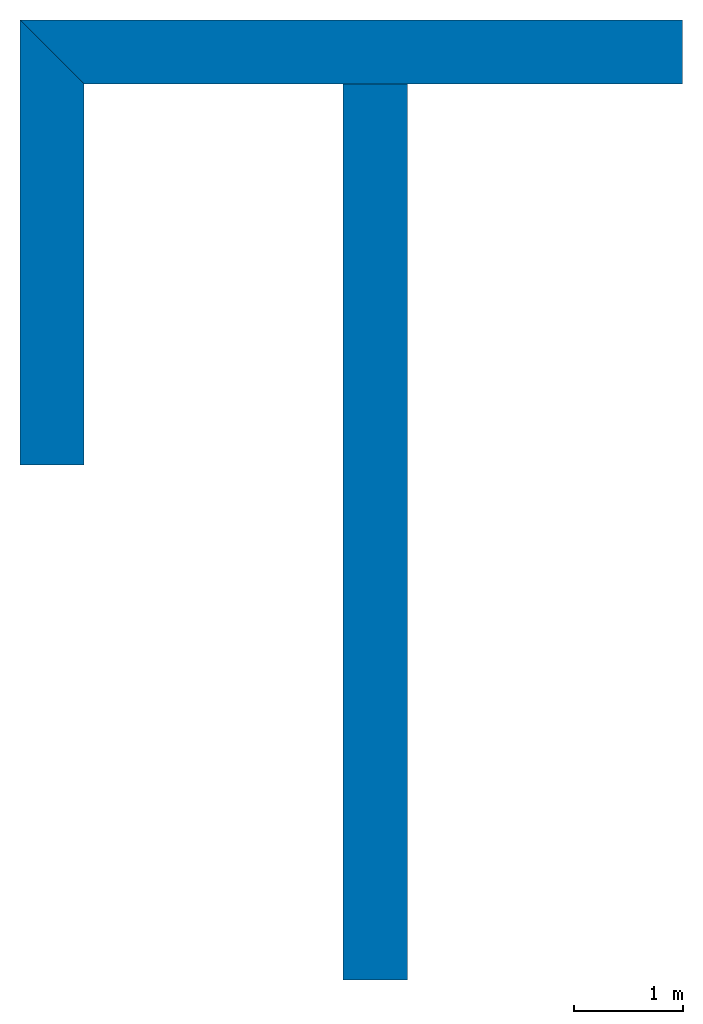
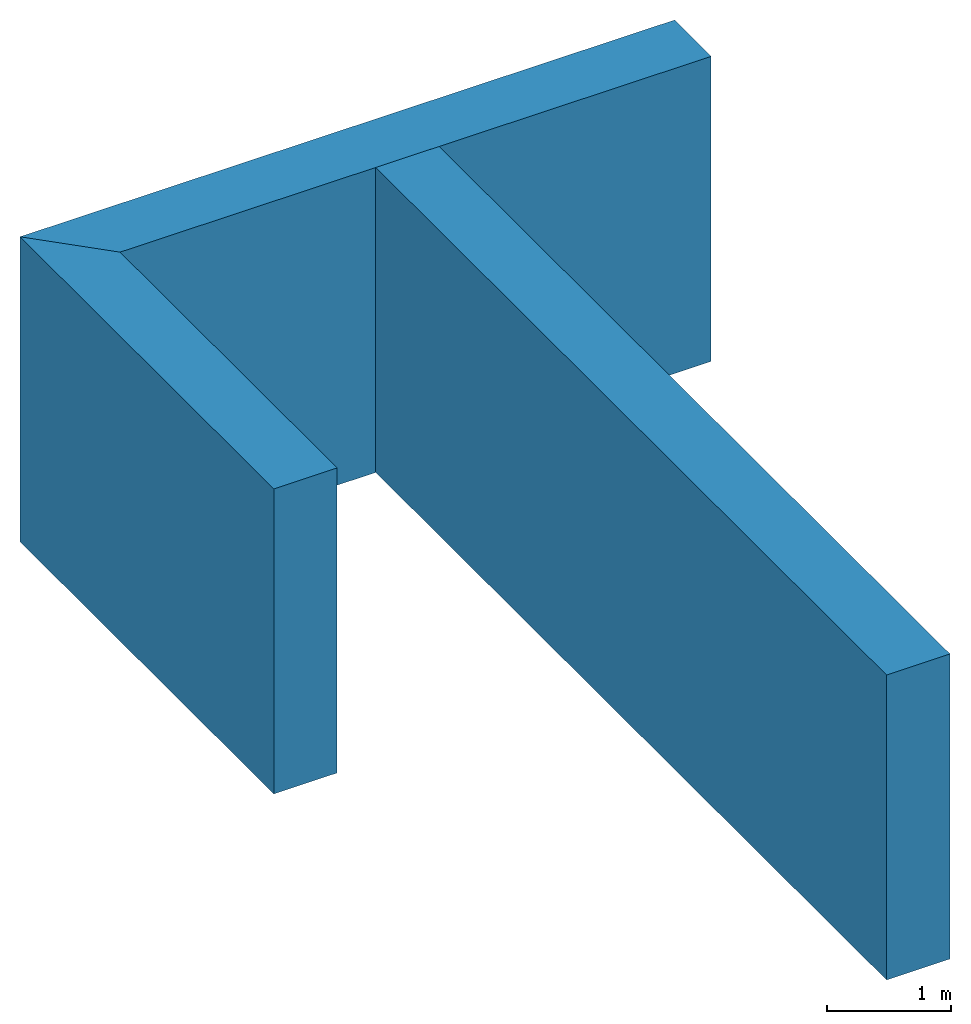
# One storey: 3 walls.
"""IFC4 building model written with IfcOpenShell, lengths in metres."""

from ifc_helpers import new_model, entity, si_unit, converted_unit, frame, origin_with_axes, origin_2d_with_axis, place, context, subcontext, project, spatial, line, indexed_curve, outline, extrude, material, layer, layer_set, layer_usage, type_object, element, save


model = new_model("IFC4")

# Units and contexts
model_context = context("Model", 3, precision=1e-05, world=origin_with_axes())
plan_context = context("Plan", 2, precision=1e-05, world=origin_2d_with_axis())
body_context = subcontext(model_context, "Body", "Model", "MODEL_VIEW")
ifc_project = project(units=[si_unit("AREAUNIT", "SQUARE_METRE"), si_unit("VOLUMEUNIT", "CUBIC_METRE"), si_unit("LENGTHUNIT", "METRE"), converted_unit("PLANEANGLEUNIT", "degree", entity("IfcReal", 0.0174532925199433), si_unit("PLANEANGLEUNIT", "RADIAN"), dimensions=[0, 0, 0, 0, 0, 0, 0])], contexts=[model_context, plan_context])

# Site, building, storey
site_placement = place(None, origin_with_axes())
site = spatial("IfcSite", under=ifc_project, at=site_placement)
building_placement = place(site_placement, origin_with_axes())
building = spatial("IfcBuilding", under=site, at=building_placement, Name="Building")
storey_placement = place(building_placement, origin_with_axes())
storey = spatial("IfcBuildingStorey", under=building, at=storey_placement, Name="Storey")

# Walls
ifc_material_1 = material(Name="Stucco")
ifc_layer_1 = layer(ifc_material_1, 0.0199999995529652, ventilated=False, Priority=80)
ifc_material_2 = material(Name="Brick")
ifc_layer_2 = layer(ifc_material_2, 0.300000011920929, Priority=20)
ifc_material_3 = material(Name="Insulation")
ifc_layer_3 = layer(ifc_material_3, 0.25, Priority=50)
ifc_layer_4 = layer(ifc_material_1, 0.0199999995529652, Priority=80)
ifc_layer_set = layer_set([ifc_layer_1, ifc_layer_2, ifc_layer_3, ifc_layer_4], Name="Brick Wall Layer Set")
ifc_layer_usage_1 = layer_usage(ifc_layer_set, "AXIS2", "POSITIVE", 0.0)
wall_type = type_object("IfcWallType", Name="Brick wall", PredefinedType="SOLIDWALL", material=ifc_layer_set)
wall_1_placement = place(storey_placement, frame((7.1723007977198e-07, 9.5, 0.0), z_axis=(0.0, 0.0, 1.0), x_axis=(1.0, -2.38418579101562e-07, 0.0)))
element("IfcWall", 1, at=wall_1_placement, inside=storey, type_object=wall_type, material=ifc_layer_usage_1, Name="Wall", context=body_context, shape_type="SweptSolid", body=[
    extrude(outline(indexed_curve([(0.0, 0.0), (-0.0200000028113789, 0.0199999995529652), (-0.320000063608517, 0.320000011473894), (-0.57000010433869, 0.570000011473894), (-0.590000107150069, 0.590000011026859), (5.50000000000024, 0.590000011026859), (5.50000000000024, 0.0)], segments=[line(1, 2, 3, 4, 5, 6, 7, 1)])), origin_with_axes(), (0.0, 0.0, 1.0), 3.0),
])
ifc_layer_usage_2 = layer_usage(ifc_layer_set, "AXIS2", "NEGATIVE", 0.0)
wall_2_placement = place(storey_placement, frame((2.37892355769873, 1.26785459701176, 0.0), z_axis=(0.0, 0.0, 1.0), x_axis=(7.54979012640431e-08, 0.999999999999997, 0.0)))
element("IfcWall", 2, at=wall_2_placement, inside=storey, type_object=wall_type, material=ifc_layer_usage_2, Name="Wall", context=body_context, shape_type="SweptSolid", body=[
    extrude(outline(indexed_curve([(0.0, -0.590000011026859), (0.0, 0.0), (8.23214483580871, 0.0), (8.2321448325503, -0.0199999995529652), (8.23214478367409, -0.320000011473894), (8.23214474294392, -0.570000011473894), (8.23214473968551, -0.590000011026859)], segments=[line(1, 2, 3, 4, 5, 6, 7, 1)])), origin_with_axes(), (0.0, 0.0, 1.0), 3.0),
])
ifc_layer_usage_3 = layer_usage(ifc_layer_set, "AXIS2", "POSITIVE", 0.0)
wall_3_placement = place(storey_placement, frame((4.52987421795115e-07, 6.0, 0.0), z_axis=(0.0, 0.0, 1.0), x_axis=(7.54979012640433e-08, 1.0, 0.0)))
element("IfcWall", 3, at=wall_3_placement, inside=storey, type_object=wall_type, material=ifc_layer_usage_3, Name="Wall", context=body_context, shape_type="SweptSolid", body=[
    extrude(outline(indexed_curve([(0.0, 0.0), (0.0, 0.590000011026859), (4.09000010715008, 0.590000011026859), (4.0700001043387, 0.570000011473894), (3.82000006360853, 0.320000011473894), (3.52000000281139, 0.0199999995529652), (3.50000000000001, 0.0)], segments=[line(1, 2, 3, 4, 5, 6, 7, 1)])), origin_with_axes(), (0.0, 0.0, 1.0), 3.0),
])

save(model, "model.ifc")
